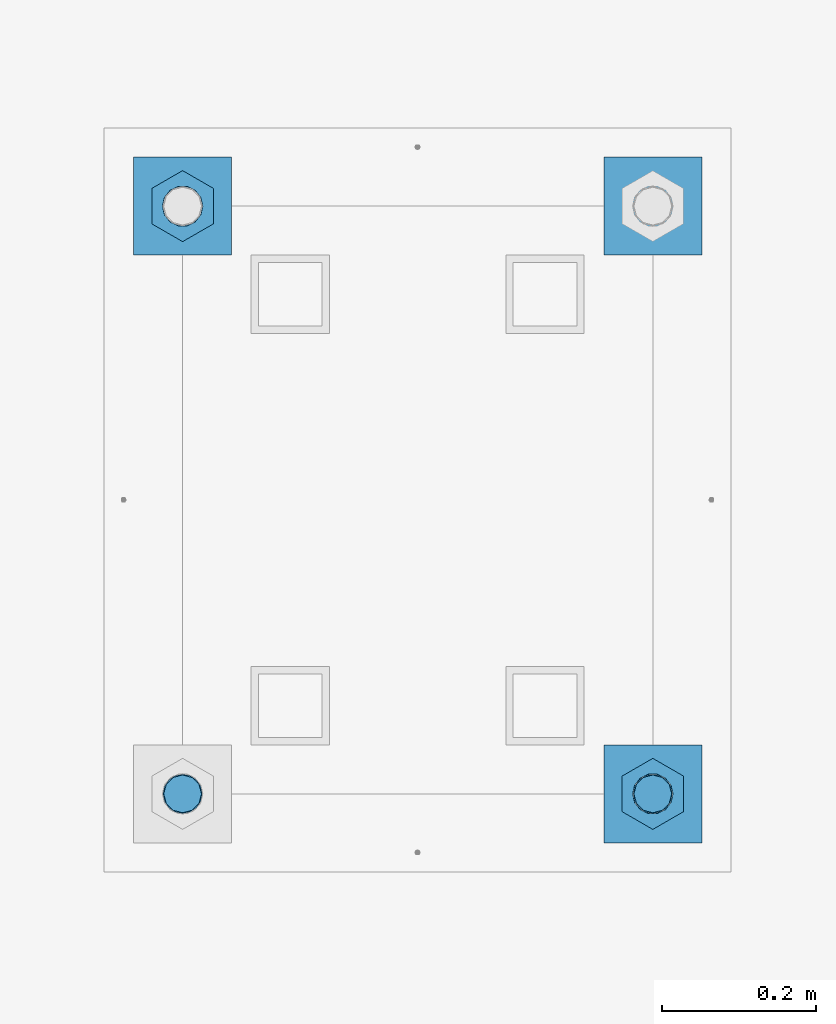
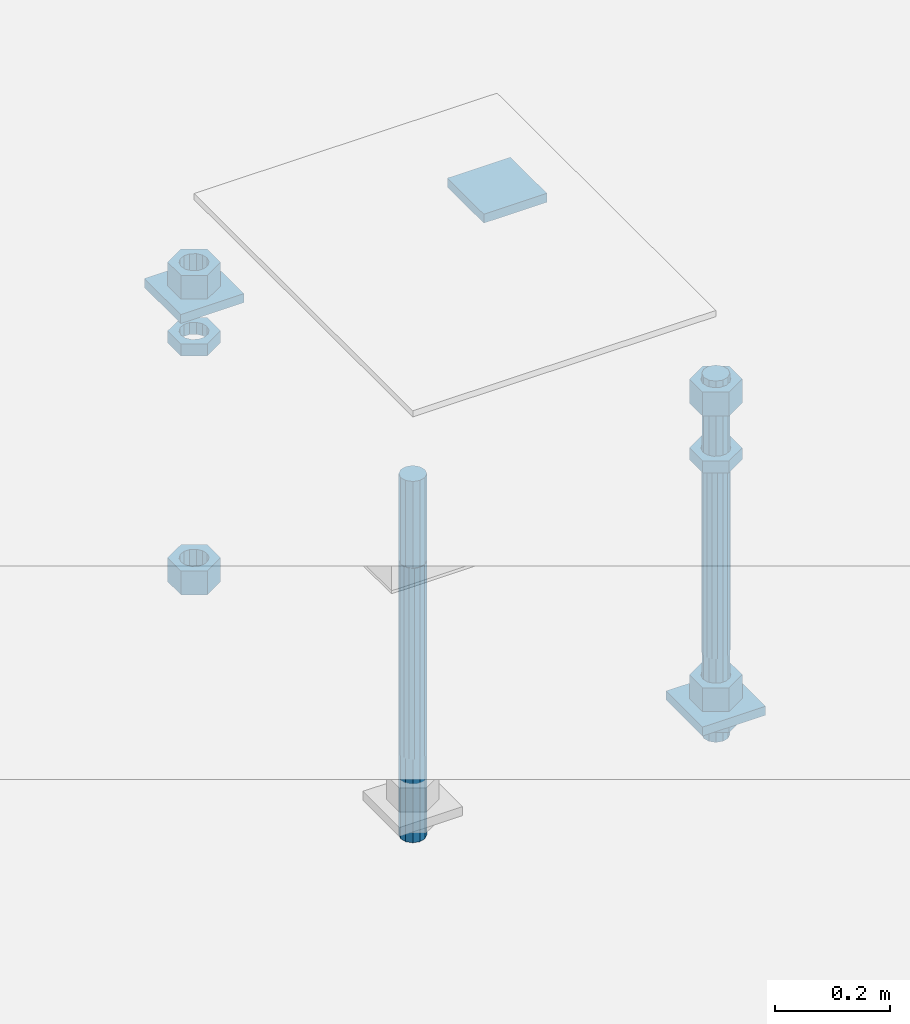
# One storey, part 2639 of 3843: 12 beams, 1 element without a shape of its own.
"""IFC2X3 building model written with IfcOpenShell, lengths in millimetres."""

from ifc_helpers import new_model, si_unit, frame, origin_with_axes, place, context, subcontext, project, spatial, faceted_brep, material, type_object, element, aggregate, save


model = new_model("IFC2X3")

# Units and contexts
model_context = context("Model", 3, precision=1e-05, world=origin_with_axes())
body_context = subcontext(model_context, "Body", "Model", "MODEL_VIEW")
ifc_project = project(units=[si_unit("LENGTHUNIT", "METRE", prefix="MILLI"), si_unit("AREAUNIT", "SQUARE_METRE"), si_unit("VOLUMEUNIT", "CUBIC_METRE"), si_unit("MASSUNIT", "GRAM", prefix="KILO"), si_unit("TIMEUNIT", "SECOND"), si_unit("PLANEANGLEUNIT", "RADIAN"), si_unit("SOLIDANGLEUNIT", "STERADIAN"), si_unit("THERMODYNAMICTEMPERATUREUNIT", "DEGREE_CELSIUS"), si_unit("LUMINOUSINTENSITYUNIT", "LUMEN")], contexts=[model_context])

# Site, building, storey
site_placement = place(None, origin_with_axes())
site = spatial("IfcSite", under=ifc_project, at=site_placement, CompositionType="ELEMENT")
building_placement = place(site_placement, origin_with_axes())
building = spatial("IfcBuilding", under=site, at=building_placement, Name="Undefined", CompositionType="ELEMENT")
storey_placement = place(building_placement, origin_with_axes())
storey = spatial("IfcBuildingStorey", under=building, at=storey_placement, Name="Undefined", CompositionType="ELEMENT", Elevation=0.0)

# Assembly, beams
assembly_placement = place(storey_placement, origin_with_axes())
assembly = element("IfcElementAssembly", 1, at=assembly_placement, inside=storey, Name="TEMPLATE", AssemblyPlace="NOTDEFINED", PredefinedType="RIGID_FRAME")
ifc_material_1 = material(Name="STEEL/A36")
beam_type_1 = type_object("IfcBeamType", PredefinedType="NOTDEFINED")
beam_1_placement = place(assembly_placement, frame((112407.7, 10883.9, 29873.575), z_axis=(0.0, 1.0, 0.0), x_axis=(-1.0, 0.0, 0.0)))
beam_1 = element("IfcBeam", 2, at=beam_1_placement, type_object=beam_type_1, material=ifc_material_1, Name="WASHER_PLATE", context=body_context, shape_type="Brep", body=[
    faceted_brep([(0.0, 9.52500000000146, -63.5), (0.0, 9.52500000000146, 63.5), (127.0, 9.52500000000146, 63.5), (127.0, 9.52500000000146, -63.5), (0.0, -9.52500000000146, 63.5), (127.0, -9.52500000000146, 63.5), (0.0, -9.52500000000146, -63.5), (127.0, -9.52500000000146, -63.5)], [[[0, 1, 2, 3]], [[1, 4, 5, 2]], [[4, 6, 7, 5]], [[6, 0, 3, 7]], [[5, 7, 3, 2]], [[6, 4, 1, 0]]]),
])
beam_2_placement = place(assembly_placement, frame((111798.099998474, 10883.9, 29873.575), z_axis=(0.0, 1.0, 0.0), x_axis=(-1.0, 0.0, 0.0)))
beam_2 = element("IfcBeam", 3, at=beam_2_placement, type_object=beam_type_1, material=ifc_material_1, Name="WASHER_PLATE", context=body_context, shape_type="Brep", body=[
    faceted_brep([(0.0, 9.52500000000146, -63.5), (0.0, 9.52500000000146, 63.5), (127.0, 9.52500000000146, 63.5), (127.0, 9.52500000000146, -63.5), (0.0, -9.52500000000146, 63.5), (127.0, -9.52500000000146, 63.5), (0.0, -9.52500000000146, -63.5), (127.0, -9.52500000000146, -63.5)], [[[0, 1, 2, 3]], [[1, 4, 5, 2]], [[4, 6, 7, 5]], [[6, 0, 3, 7]], [[5, 7, 3, 2]], [[6, 4, 1, 0]]]),
])
beam_3_placement = place(assembly_placement, frame((112407.7, 10121.9, 29244.925), z_axis=(0.0, 1.0, 0.0), x_axis=(-1.0, 0.0, 0.0)))
beam_3 = element("IfcBeam", 4, at=beam_3_placement, type_object=beam_type_1, material=ifc_material_1, Name="WASHER_PLATE", context=body_context, shape_type="Brep", body=[
    faceted_brep([(0.0, 9.52500000000146, -63.5), (0.0, 9.52500000000146, 63.5), (127.0, 9.52500000000146, 63.5), (127.0, 9.52500000000146, -63.5), (0.0, -9.52500000000146, 63.5), (127.0, -9.52500000000146, 63.5), (0.0, -9.52500000000146, -63.5), (127.0, -9.52500000000146, -63.5)], [[[0, 1, 2, 3]], [[1, 4, 5, 2]], [[4, 6, 7, 5]], [[6, 0, 3, 7]], [[5, 7, 3, 2]], [[6, 4, 1, 0]]]),
])
beam_type_2 = type_object("IfcBeamType", Name="2_HALF_NUT", PredefinedType="NOTDEFINED")
beam_4_placement = place(assembly_placement, frame((111734.599998474, 10883.9, 29787.85), z_axis=(-1.0, 0.0, 0.0), x_axis=(0.0, 0.0, -1.0)))
beam_4 = element("IfcBeam", 5, at=beam_4_placement, type_object=beam_type_2, material=ifc_material_1, Name="NUT", ObjectType="2_HALF_NUT", context=body_context, shape_type="Brep", body=[
    faceted_brep([(0.0, -46.0369987487793, 0.0), (0.0, -23.0184993743896, -39.869213104248), (25.4000000000015, -23.0184993743896, -39.869213104248), (25.4000000000015, -46.0369987487793, 0.0), (0.0, 23.0184993743896, -39.869213104248), (25.4000000000015, 23.0184993743896, -39.869213104248), (0.0, 46.0369987487793, 0.0), (25.4000000000015, 46.0369987487793, 0.0), (0.0, 23.0184993743896, 39.869213104248), (25.4000000000015, 23.0184993743896, 39.869213104248), (0.0, -23.0184993743896, 39.869213104248), (25.4000000000015, -23.0184993743896, 39.869213104248), (0.0, 0.0, 26.1940002441406), (0.0, 11.3650617044477, 23.5999013092805), (25.4000000000015, 11.3650617044477, 23.5999013092805), (25.4000000000015, 0.0, 26.1940002441406), (0.0, 20.4791109456419, 16.3316083006721), (25.4000000000015, 20.4791109456419, 16.3316083006721), (0.0, 25.5370200498292, 5.82867859874386), (25.4000000000015, 25.5370200498292, 5.82867859874386), (0.0, 25.5370200498292, -5.82867859874386), (25.4000000000015, 25.5370200498292, -5.82867859874386), (0.0, 20.4791109456419, -16.3316083006721), (25.4000000000015, 20.4791109456419, -16.3316083006721), (0.0, 11.3650617044477, -23.5999013092805), (25.4000000000015, 11.3650617044477, -23.5999013092805), (0.0, 0.0, -26.1940002441406), (25.4000000000015, 0.0, -26.1940002441406), (0.0, -11.3650617044477, -23.5999013092805), (25.4000000000015, -11.3650617044477, -23.5999013092805), (0.0, -20.4791109456419, -16.3316083006721), (25.4000000000015, -20.4791109456419, -16.3316083006721), (0.0, -25.5370200498292, -5.82867859874386), (25.4000000000015, -25.5370200498292, -5.82867859874386), (0.0, -25.5370200498292, 5.82867859874386), (25.4000000000015, -25.5370200498292, 5.82867859874386), (0.0, -20.4791109456419, 16.3316083006721), (25.4000000000015, -20.4791109456419, 16.3316083006721), (0.0, -11.3650617044477, 23.5999013092805), (25.4000000000015, -11.3650617044477, 23.5999013092805)], [[[0, 1, 2, 3]], [[1, 4, 5, 2]], [[4, 6, 7, 5]], [[6, 8, 9, 7]], [[8, 10, 11, 9]], [[10, 0, 3, 11]], [[12, 13, 14, 15]], [[13, 16, 17, 14]], [[16, 18, 19, 17]], [[18, 20, 21, 19]], [[20, 22, 23, 21]], [[22, 24, 25, 23]], [[24, 26, 27, 25]], [[26, 28, 29, 27]], [[28, 30, 31, 29]], [[30, 32, 33, 31]], [[32, 34, 35, 33]], [[34, 36, 37, 35]], [[36, 38, 39, 37]], [[38, 12, 15, 39]], [[5, 7, 9, 11, 3, 2], [17, 19, 21, 23, 25, 27, 29, 31, 33, 35, 37, 39, 15, 14]], [[10, 8, 6, 4, 1, 0], [38, 36, 34, 32, 30, 28, 26, 24, 22, 20, 18, 16, 13, 12]]]),
])
beam_5_placement = place(assembly_placement, frame((112344.2, 10121.9, 29787.85), z_axis=(-1.0, 0.0, 0.0), x_axis=(0.0, 0.0, -1.0)))
beam_5 = element("IfcBeam", 6, at=beam_5_placement, type_object=beam_type_2, material=ifc_material_1, Name="NUT", ObjectType="2_HALF_NUT", context=body_context, shape_type="Brep", body=[
    faceted_brep([(0.0, -46.0369987487793, 0.0), (0.0, -23.0184993743896, -39.869213104248), (25.4000000000015, -23.0184993743896, -39.869213104248), (25.4000000000015, -46.0369987487793, 0.0), (0.0, 23.0184993743896, -39.869213104248), (25.4000000000015, 23.0184993743896, -39.869213104248), (0.0, 46.0369987487793, 0.0), (25.4000000000015, 46.0369987487793, 0.0), (0.0, 23.0184993743896, 39.869213104248), (25.4000000000015, 23.0184993743896, 39.869213104248), (0.0, -23.0184993743896, 39.869213104248), (25.4000000000015, -23.0184993743896, 39.869213104248), (0.0, 0.0, 26.1940002441406), (0.0, 11.3650617044477, 23.5999013092805), (25.4000000000015, 11.3650617044477, 23.5999013092805), (25.4000000000015, 0.0, 26.1940002441406), (0.0, 20.4791109456419, 16.3316083006721), (25.4000000000015, 20.4791109456419, 16.3316083006721), (0.0, 25.5370200498292, 5.82867859874386), (25.4000000000015, 25.5370200498292, 5.82867859874386), (0.0, 25.5370200498292, -5.82867859874386), (25.4000000000015, 25.5370200498292, -5.82867859874386), (0.0, 20.4791109456419, -16.3316083006721), (25.4000000000015, 20.4791109456419, -16.3316083006721), (0.0, 11.3650617044477, -23.5999013092805), (25.4000000000015, 11.3650617044477, -23.5999013092805), (0.0, 0.0, -26.1940002441406), (25.4000000000015, 0.0, -26.1940002441406), (0.0, -11.3650617044477, -23.5999013092805), (25.4000000000015, -11.3650617044477, -23.5999013092805), (0.0, -20.4791109456419, -16.3316083006721), (25.4000000000015, -20.4791109456419, -16.3316083006721), (0.0, -25.5370200498292, -5.82867859874386), (25.4000000000015, -25.5370200498292, -5.82867859874386), (0.0, -25.5370200498292, 5.82867859874386), (25.4000000000015, -25.5370200498292, 5.82867859874386), (0.0, -20.4791109456419, 16.3316083006721), (25.4000000000015, -20.4791109456419, 16.3316083006721), (0.0, -11.3650617044477, 23.5999013092805), (25.4000000000015, -11.3650617044477, 23.5999013092805)], [[[0, 1, 2, 3]], [[1, 4, 5, 2]], [[4, 6, 7, 5]], [[6, 8, 9, 7]], [[8, 10, 11, 9]], [[10, 0, 3, 11]], [[12, 13, 14, 15]], [[13, 16, 17, 14]], [[16, 18, 19, 17]], [[18, 20, 21, 19]], [[20, 22, 23, 21]], [[22, 24, 25, 23]], [[24, 26, 27, 25]], [[26, 28, 29, 27]], [[28, 30, 31, 29]], [[30, 32, 33, 31]], [[32, 34, 35, 33]], [[34, 36, 37, 35]], [[36, 38, 39, 37]], [[38, 12, 15, 39]], [[5, 7, 9, 11, 3, 2], [17, 19, 21, 23, 25, 27, 29, 31, 33, 35, 37, 39, 15, 14]], [[10, 8, 6, 4, 1, 0], [38, 36, 34, 32, 30, 28, 26, 24, 22, 20, 18, 16, 13, 12]]]),
])
beam_6_placement = place(assembly_placement, frame((112344.2, 10121.9, 29235.4), z_axis=(-1.0, 0.0, 0.0), x_axis=(0.0, 0.0, -1.0)))
beam_6 = element("IfcBeam", 7, at=beam_6_placement, type_object=beam_type_2, material=ifc_material_1, Name="NUT", ObjectType="2_HALF_NUT", context=body_context, shape_type="Brep", body=[
    faceted_brep([(0.0, -46.0369987487793, 0.0), (0.0, -23.0184993743896, -39.869213104248), (25.4000000000015, -23.0184993743896, -39.869213104248), (25.4000000000015, -46.0369987487793, 0.0), (0.0, 23.0184993743896, -39.869213104248), (25.4000000000015, 23.0184993743896, -39.869213104248), (0.0, 46.0369987487793, 0.0), (25.4000000000015, 46.0369987487793, 0.0), (0.0, 23.0184993743896, 39.869213104248), (25.4000000000015, 23.0184993743896, 39.869213104248), (0.0, -23.0184993743896, 39.869213104248), (25.4000000000015, -23.0184993743896, 39.869213104248), (0.0, 0.0, 26.1940002441406), (0.0, 11.3650617044477, 23.5999013092805), (25.4000000000015, 11.3650617044477, 23.5999013092805), (25.4000000000015, 0.0, 26.1940002441406), (0.0, 20.4791109456419, 16.3316083006721), (25.4000000000015, 20.4791109456419, 16.3316083006721), (0.0, 25.5370200498292, 5.82867859874386), (25.4000000000015, 25.5370200498292, 5.82867859874386), (0.0, 25.5370200498292, -5.82867859874386), (25.4000000000015, 25.5370200498292, -5.82867859874386), (0.0, 20.4791109456419, -16.3316083006721), (25.4000000000015, 20.4791109456419, -16.3316083006721), (0.0, 11.3650617044477, -23.5999013092805), (25.4000000000015, 11.3650617044477, -23.5999013092805), (0.0, 0.0, -26.1940002441406), (25.4000000000015, 0.0, -26.1940002441406), (0.0, -11.3650617044477, -23.5999013092805), (25.4000000000015, -11.3650617044477, -23.5999013092805), (0.0, -20.4791109456419, -16.3316083006721), (25.4000000000015, -20.4791109456419, -16.3316083006721), (0.0, -25.5370200498292, -5.82867859874386), (25.4000000000015, -25.5370200498292, -5.82867859874386), (0.0, -25.5370200498292, 5.82867859874386), (25.4000000000015, -25.5370200498292, 5.82867859874386), (0.0, -20.4791109456419, 16.3316083006721), (25.4000000000015, -20.4791109456419, 16.3316083006721), (0.0, -11.3650617044477, 23.5999013092805), (25.4000000000015, -11.3650617044477, 23.5999013092805)], [[[0, 1, 2, 3]], [[1, 4, 5, 2]], [[4, 6, 7, 5]], [[6, 8, 9, 7]], [[8, 10, 11, 9]], [[10, 0, 3, 11]], [[12, 13, 14, 15]], [[13, 16, 17, 14]], [[16, 18, 19, 17]], [[18, 20, 21, 19]], [[20, 22, 23, 21]], [[22, 24, 25, 23]], [[24, 26, 27, 25]], [[26, 28, 29, 27]], [[28, 30, 31, 29]], [[30, 32, 33, 31]], [[32, 34, 35, 33]], [[34, 36, 37, 35]], [[36, 38, 39, 37]], [[38, 12, 15, 39]], [[5, 7, 9, 11, 3, 2], [17, 19, 21, 23, 25, 27, 29, 31, 33, 35, 37, 39, 15, 14]], [[10, 8, 6, 4, 1, 0], [38, 36, 34, 32, 30, 28, 26, 24, 22, 20, 18, 16, 13, 12]]]),
])
beam_type_3 = type_object("IfcBeamType", Name="2_HEAVY_HEX_NUT", PredefinedType="NOTDEFINED")
beam_7_placement = place(assembly_placement, frame((111734.599998474, 10883.9, 29933.9), z_axis=(-1.0, 0.0, 0.0), x_axis=(0.0, 0.0, -1.0)))
beam_7 = element("IfcBeam", 8, at=beam_7_placement, type_object=beam_type_3, material=ifc_material_1, Name="NUT", ObjectType="2_HEAVY_HEX_NUT", context=body_context, shape_type="Brep", body=[
    faceted_brep([(0.0, -46.0369987487793, 0.0), (0.0, -23.0184993743896, -39.869213104248), (50.7999999999993, -23.0184993743896, -39.869213104248), (50.7999999999993, -46.0369987487793, 0.0), (0.0, 23.0184993743896, -39.869213104248), (50.7999999999993, 23.0184993743896, -39.869213104248), (0.0, 46.0369987487793, 0.0), (50.7999999999993, 46.0369987487793, 0.0), (0.0, 23.0184993743896, 39.869213104248), (50.7999999999993, 23.0184993743896, 39.869213104248), (0.0, -23.0184993743896, 39.869213104248), (50.7999999999993, -23.0184993743896, 39.869213104248), (0.0, 0.0, 26.1940002441406), (0.0, 11.3650617044477, 23.5999013092805), (50.7999999999993, 11.3650617044477, 23.5999013092805), (50.7999999999993, 0.0, 26.1940002441406), (0.0, 20.4791109456419, 16.3316083006721), (50.7999999999993, 20.4791109456419, 16.3316083006721), (0.0, 25.5370200498292, 5.82867859874386), (50.7999999999993, 25.5370200498292, 5.82867859874386), (0.0, 25.5370200498292, -5.82867859874386), (50.7999999999993, 25.5370200498292, -5.82867859874386), (0.0, 20.4791109456419, -16.3316083006721), (50.7999999999993, 20.4791109456419, -16.3316083006721), (0.0, 11.3650617044477, -23.5999013092805), (50.7999999999993, 11.3650617044477, -23.5999013092805), (0.0, 0.0, -26.1940002441406), (50.7999999999993, 0.0, -26.1940002441406), (0.0, -11.3650617044477, -23.5999013092805), (50.7999999999993, -11.3650617044477, -23.5999013092805), (0.0, -20.4791109456419, -16.3316083006721), (50.7999999999993, -20.4791109456419, -16.3316083006721), (0.0, -25.5370200498292, -5.82867859874386), (50.7999999999993, -25.5370200498292, -5.82867859874386), (0.0, -25.5370200498292, 5.82867859874386), (50.7999999999993, -25.5370200498292, 5.82867859874386), (0.0, -20.4791109456419, 16.3316083006721), (50.7999999999993, -20.4791109456419, 16.3316083006721), (0.0, -11.3650617044477, 23.5999013092805), (50.7999999999993, -11.3650617044477, 23.5999013092805)], [[[0, 1, 2, 3]], [[1, 4, 5, 2]], [[4, 6, 7, 5]], [[6, 8, 9, 7]], [[8, 10, 11, 9]], [[10, 0, 3, 11]], [[12, 13, 14, 15]], [[13, 16, 17, 14]], [[16, 18, 19, 17]], [[18, 20, 21, 19]], [[20, 22, 23, 21]], [[22, 24, 25, 23]], [[24, 26, 27, 25]], [[26, 28, 29, 27]], [[28, 30, 31, 29]], [[30, 32, 33, 31]], [[32, 34, 35, 33]], [[34, 36, 37, 35]], [[36, 38, 39, 37]], [[38, 12, 15, 39]], [[5, 7, 9, 11, 3, 2], [17, 19, 21, 23, 25, 27, 29, 31, 33, 35, 37, 39, 15, 14]], [[10, 8, 6, 4, 1, 0], [38, 36, 34, 32, 30, 28, 26, 24, 22, 20, 18, 16, 13, 12]]]),
])
beam_8_placement = place(assembly_placement, frame((111734.599998474, 10883.9, 29305.25), z_axis=(-1.0, 0.0, 0.0), x_axis=(0.0, 0.0, -1.0)))
beam_8 = element("IfcBeam", 9, at=beam_8_placement, type_object=beam_type_3, material=ifc_material_1, Name="NUT", ObjectType="2_HEAVY_HEX_NUT", context=body_context, shape_type="Brep", body=[
    faceted_brep([(0.0, -46.0369987487793, 0.0), (0.0, -23.0184993743896, -39.869213104248), (50.7999999999993, -23.0184993743896, -39.869213104248), (50.7999999999993, -46.0369987487793, 0.0), (0.0, 23.0184993743896, -39.869213104248), (50.7999999999993, 23.0184993743896, -39.869213104248), (0.0, 46.0369987487793, 0.0), (50.7999999999993, 46.0369987487793, 0.0), (0.0, 23.0184993743896, 39.869213104248), (50.7999999999993, 23.0184993743896, 39.869213104248), (0.0, -23.0184993743896, 39.869213104248), (50.7999999999993, -23.0184993743896, 39.869213104248), (0.0, 0.0, 26.1940002441406), (0.0, 11.3650617044477, 23.5999013092805), (50.7999999999993, 11.3650617044477, 23.5999013092805), (50.7999999999993, 0.0, 26.1940002441406), (0.0, 20.4791109456419, 16.3316083006721), (50.7999999999993, 20.4791109456419, 16.3316083006721), (0.0, 25.5370200498292, 5.82867859874386), (50.7999999999993, 25.5370200498292, 5.82867859874386), (0.0, 25.5370200498292, -5.82867859874386), (50.7999999999993, 25.5370200498292, -5.82867859874386), (0.0, 20.4791109456419, -16.3316083006721), (50.7999999999993, 20.4791109456419, -16.3316083006721), (0.0, 11.3650617044477, -23.5999013092805), (50.7999999999993, 11.3650617044477, -23.5999013092805), (0.0, 0.0, -26.1940002441406), (50.7999999999993, 0.0, -26.1940002441406), (0.0, -11.3650617044477, -23.5999013092805), (50.7999999999993, -11.3650617044477, -23.5999013092805), (0.0, -20.4791109456419, -16.3316083006721), (50.7999999999993, -20.4791109456419, -16.3316083006721), (0.0, -25.5370200498292, -5.82867859874386), (50.7999999999993, -25.5370200498292, -5.82867859874386), (0.0, -25.5370200498292, 5.82867859874386), (50.7999999999993, -25.5370200498292, 5.82867859874386), (0.0, -20.4791109456419, 16.3316083006721), (50.7999999999993, -20.4791109456419, 16.3316083006721), (0.0, -11.3650617044477, 23.5999013092805), (50.7999999999993, -11.3650617044477, 23.5999013092805)], [[[0, 1, 2, 3]], [[1, 4, 5, 2]], [[4, 6, 7, 5]], [[6, 8, 9, 7]], [[8, 10, 11, 9]], [[10, 0, 3, 11]], [[12, 13, 14, 15]], [[13, 16, 17, 14]], [[16, 18, 19, 17]], [[18, 20, 21, 19]], [[20, 22, 23, 21]], [[22, 24, 25, 23]], [[24, 26, 27, 25]], [[26, 28, 29, 27]], [[28, 30, 31, 29]], [[30, 32, 33, 31]], [[32, 34, 35, 33]], [[34, 36, 37, 35]], [[36, 38, 39, 37]], [[38, 12, 15, 39]], [[5, 7, 9, 11, 3, 2], [17, 19, 21, 23, 25, 27, 29, 31, 33, 35, 37, 39, 15, 14]], [[10, 8, 6, 4, 1, 0], [38, 36, 34, 32, 30, 28, 26, 24, 22, 20, 18, 16, 13, 12]]]),
])
beam_9_placement = place(assembly_placement, frame((112344.2, 10121.9, 29933.9), z_axis=(-1.0, 0.0, 0.0), x_axis=(0.0, 0.0, -1.0)))
beam_9 = element("IfcBeam", 10, at=beam_9_placement, type_object=beam_type_3, material=ifc_material_1, Name="NUT", ObjectType="2_HEAVY_HEX_NUT", context=body_context, shape_type="Brep", body=[
    faceted_brep([(0.0, -46.0369987487793, 0.0), (0.0, -23.0184993743896, -39.869213104248), (50.7999999999993, -23.0184993743896, -39.869213104248), (50.7999999999993, -46.0369987487793, 0.0), (0.0, 23.0184993743896, -39.869213104248), (50.7999999999993, 23.0184993743896, -39.869213104248), (0.0, 46.0369987487793, 0.0), (50.7999999999993, 46.0369987487793, 0.0), (0.0, 23.0184993743896, 39.869213104248), (50.7999999999993, 23.0184993743896, 39.869213104248), (0.0, -23.0184993743896, 39.869213104248), (50.7999999999993, -23.0184993743896, 39.869213104248), (0.0, 0.0, 26.1940002441406), (0.0, 11.3650617044477, 23.5999013092805), (50.7999999999993, 11.3650617044477, 23.5999013092805), (50.7999999999993, 0.0, 26.1940002441406), (0.0, 20.4791109456419, 16.3316083006721), (50.7999999999993, 20.4791109456419, 16.3316083006721), (0.0, 25.5370200498292, 5.82867859874386), (50.7999999999993, 25.5370200498292, 5.82867859874386), (0.0, 25.5370200498292, -5.82867859874386), (50.7999999999993, 25.5370200498292, -5.82867859874386), (0.0, 20.4791109456419, -16.3316083006721), (50.7999999999993, 20.4791109456419, -16.3316083006721), (0.0, 11.3650617044477, -23.5999013092805), (50.7999999999993, 11.3650617044477, -23.5999013092805), (0.0, 0.0, -26.1940002441406), (50.7999999999993, 0.0, -26.1940002441406), (0.0, -11.3650617044477, -23.5999013092805), (50.7999999999993, -11.3650617044477, -23.5999013092805), (0.0, -20.4791109456419, -16.3316083006721), (50.7999999999993, -20.4791109456419, -16.3316083006721), (0.0, -25.5370200498292, -5.82867859874386), (50.7999999999993, -25.5370200498292, -5.82867859874386), (0.0, -25.5370200498292, 5.82867859874386), (50.7999999999993, -25.5370200498292, 5.82867859874386), (0.0, -20.4791109456419, 16.3316083006721), (50.7999999999993, -20.4791109456419, 16.3316083006721), (0.0, -11.3650617044477, 23.5999013092805), (50.7999999999993, -11.3650617044477, 23.5999013092805)], [[[0, 1, 2, 3]], [[1, 4, 5, 2]], [[4, 6, 7, 5]], [[6, 8, 9, 7]], [[8, 10, 11, 9]], [[10, 0, 3, 11]], [[12, 13, 14, 15]], [[13, 16, 17, 14]], [[16, 18, 19, 17]], [[18, 20, 21, 19]], [[20, 22, 23, 21]], [[22, 24, 25, 23]], [[24, 26, 27, 25]], [[26, 28, 29, 27]], [[28, 30, 31, 29]], [[30, 32, 33, 31]], [[32, 34, 35, 33]], [[34, 36, 37, 35]], [[36, 38, 39, 37]], [[38, 12, 15, 39]], [[5, 7, 9, 11, 3, 2], [17, 19, 21, 23, 25, 27, 29, 31, 33, 35, 37, 39, 15, 14]], [[10, 8, 6, 4, 1, 0], [38, 36, 34, 32, 30, 28, 26, 24, 22, 20, 18, 16, 13, 12]]]),
])
beam_10_placement = place(assembly_placement, frame((112344.2, 10121.9, 29305.25), z_axis=(-1.0, 0.0, 0.0), x_axis=(0.0, 0.0, -1.0)))
beam_10 = element("IfcBeam", 11, at=beam_10_placement, type_object=beam_type_3, material=ifc_material_1, Name="NUT", ObjectType="2_HEAVY_HEX_NUT", context=body_context, shape_type="Brep", body=[
    faceted_brep([(0.0, -46.0369987487793, 0.0), (0.0, -23.0184993743896, -39.869213104248), (50.7999999999993, -23.0184993743896, -39.869213104248), (50.7999999999993, -46.0369987487793, 0.0), (0.0, 23.0184993743896, -39.869213104248), (50.7999999999993, 23.0184993743896, -39.869213104248), (0.0, 46.0369987487793, 0.0), (50.7999999999993, 46.0369987487793, 0.0), (0.0, 23.0184993743896, 39.869213104248), (50.7999999999993, 23.0184993743896, 39.869213104248), (0.0, -23.0184993743896, 39.869213104248), (50.7999999999993, -23.0184993743896, 39.869213104248), (0.0, 0.0, 26.1940002441406), (0.0, 11.3650617044477, 23.5999013092805), (50.7999999999993, 11.3650617044477, 23.5999013092805), (50.7999999999993, 0.0, 26.1940002441406), (0.0, 20.4791109456419, 16.3316083006721), (50.7999999999993, 20.4791109456419, 16.3316083006721), (0.0, 25.5370200498292, 5.82867859874386), (50.7999999999993, 25.5370200498292, 5.82867859874386), (0.0, 25.5370200498292, -5.82867859874386), (50.7999999999993, 25.5370200498292, -5.82867859874386), (0.0, 20.4791109456419, -16.3316083006721), (50.7999999999993, 20.4791109456419, -16.3316083006721), (0.0, 11.3650617044477, -23.5999013092805), (50.7999999999993, 11.3650617044477, -23.5999013092805), (0.0, 0.0, -26.1940002441406), (50.7999999999993, 0.0, -26.1940002441406), (0.0, -11.3650617044477, -23.5999013092805), (50.7999999999993, -11.3650617044477, -23.5999013092805), (0.0, -20.4791109456419, -16.3316083006721), (50.7999999999993, -20.4791109456419, -16.3316083006721), (0.0, -25.5370200498292, -5.82867859874386), (50.7999999999993, -25.5370200498292, -5.82867859874386), (0.0, -25.5370200498292, 5.82867859874386), (50.7999999999993, -25.5370200498292, 5.82867859874386), (0.0, -20.4791109456419, 16.3316083006721), (50.7999999999993, -20.4791109456419, 16.3316083006721), (0.0, -11.3650617044477, 23.5999013092805), (50.7999999999993, -11.3650617044477, 23.5999013092805)], [[[0, 1, 2, 3]], [[1, 4, 5, 2]], [[4, 6, 7, 5]], [[6, 8, 9, 7]], [[8, 10, 11, 9]], [[10, 0, 3, 11]], [[12, 13, 14, 15]], [[13, 16, 17, 14]], [[16, 18, 19, 17]], [[18, 20, 21, 19]], [[20, 22, 23, 21]], [[22, 24, 25, 23]], [[24, 26, 27, 25]], [[26, 28, 29, 27]], [[28, 30, 31, 29]], [[30, 32, 33, 31]], [[32, 34, 35, 33]], [[34, 36, 37, 35]], [[36, 38, 39, 37]], [[38, 12, 15, 39]], [[5, 7, 9, 11, 3, 2], [17, 19, 21, 23, 25, 27, 29, 31, 33, 35, 37, 39, 15, 14]], [[10, 8, 6, 4, 1, 0], [38, 36, 34, 32, 30, 28, 26, 24, 22, 20, 18, 16, 13, 12]]]),
])
ifc_material_2 = material()
beam_type_4 = type_object("IfcBeamType", PredefinedType="NOTDEFINED")
beam_11_placement = place(assembly_placement, frame((111734.599998474, 10121.9, 29762.45), z_axis=(-1.0, 0.0, 0.0), x_axis=(0.0, 0.0, -1.0)))
beam_11 = element("IfcBeam", 12, at=beam_11_placement, type_object=beam_type_4, material=ifc_material_2, Name="ANCHOR_ROD", context=body_context, shape_type="Brep", body=[
    faceted_brep([(-184.150000000001, -21.217622392709, 12.25), (-184.150000000001, -12.2499999999854, 21.2176223927163), (-184.150000000001, 1.45519152283669e-11, 24.5), (-184.150000000001, 12.2500000000146, 21.2176223927163), (-184.150000000001, 21.2176223927381, 12.25), (-184.150000000001, 24.5000000000146, 0.0), (-184.150000000001, 21.2176223927381, -12.25), (-184.150000000001, 12.2500000000146, -21.2176223927163), (-184.150000000001, 1.45519152283669e-11, -24.5), (-184.150000000001, -12.2499999999854, -21.2176223927163), (-184.150000000001, -21.217622392709, -12.25), (-184.150000000001, -24.4999999999854, 0.0), (0.0, 24.5000000000146, 0.0), (0.0, 21.2176223927381, -12.25), (0.0, 12.2500000000146, -21.2176223927163), (0.0, 1.45519152283669e-11, -24.5), (0.0, -12.2499999999854, -21.2176223927163), (0.0, -21.217622392709, -12.25), (0.0, -24.4999999999854, 0.0), (0.0, -21.217622392709, 12.25), (0.0, -12.2499999999854, 21.2176223927163), (0.0, 1.45519152283669e-11, 24.5), (0.0, 12.2500000000146, 21.2176223927163), (0.0, 21.2176223927381, 12.25), (0.0, -23.4665401257807, 9.72015918207035), (0.0, -17.9605122421344, 17.9605122421417), (0.0, -9.72015918207762, 23.466540125788), (0.0, 0.0, 25.4000000000015), (0.0, 9.72015918207762, 23.466540125788), (0.0, 17.9605122421344, 17.9605122421417), (0.0, 23.4665401257807, 9.72015918207035), (0.0, 25.3999996185303, 0.0), (0.0, 23.4665401257807, -9.72015918207035), (0.0, 17.9605122421344, -17.9605122421417), (0.0, 9.72015918207762, -23.466540125788), (0.0, 0.0, -25.4000000000015), (0.0, -9.72015918207762, -23.466540125788), (0.0, -17.9605122421344, -17.9605122421417), (0.0, -23.4665401257807, -9.72015918207035), (0.0, -25.3999996185303, 0.0), (406.399999999998, -25.3999999999942, 0.0), (406.399999999998, -23.4665401257807, 9.72015918207035), (406.399999999998, -17.9605122421344, 17.9605122421417), (406.399999999998, -9.72015918207762, 23.466540125788), (406.399999999998, 0.0, 25.4000000000015), (406.399999999998, 9.72015918207762, 23.466540125788), (406.399999999998, 17.9605122421344, 17.9605122421417), (406.399999999998, 23.4665401257807, 9.72015918207035), (406.399999999998, 25.3999999999942, 0.0), (406.399999999998, 23.4665401257807, -9.72015918207035), (406.399999999998, 17.9605122421344, -17.9605122421417), (406.399999999998, 9.72015918207762, -23.466540125788), (406.399999999998, 0.0, -25.4000000000015), (406.399999999998, -9.72015918207762, -23.466540125788), (406.399999999998, -17.9605122421344, -17.9605122421417), (406.399999999998, -23.4665401257807, -9.72015918207035), (406.399999999998, -12.2499999999854, 21.2176223927163), (406.399999999998, 1.45519152283669e-11, 24.5), (406.399999999998, 12.2500000000146, 21.2176223927163), (406.399999999998, 21.2176223927381, 12.25), (406.399999999998, 24.5000000000146, 0.0), (406.399999999998, 21.2176223927381, -12.25), (406.399999999998, 12.2500000000146, -21.2176223927163), (406.399999999998, 1.45519152283669e-11, -24.5), (406.399999999998, -12.2499999999854, -21.2176223927163), (406.399999999998, -21.217622392709, -12.25), (406.399999999998, -24.4999999999854, 0.0), (406.399999999998, -21.217622392709, 12.25), (584.200000000001, -12.2499999999854, -21.2176223927163), (584.200000000001, 1.45519152283669e-11, -24.5), (584.200000000001, 12.2500000000146, -21.2176223927163), (584.200000000001, 21.2176223927381, -12.25), (584.200000000001, 24.5000000000146, 0.0), (584.200000000001, 21.2176223927381, 12.25), (584.200000000001, 12.2500000000146, 21.2176223927163), (584.200000000001, 1.45519152283669e-11, 24.5), (584.200000000001, -12.2499999999854, 21.2176223927163), (584.200000000001, -21.217622392709, 12.25), (584.200000000001, -24.4999999999854, 0.0), (584.200000000001, -21.217622392709, -12.25)], [[[0, 1, 2, 3, 4, 5, 6, 7, 8, 9, 10, 11]], [[6, 5, 12, 13]], [[7, 6, 13, 14]], [[8, 7, 14, 15]], [[9, 8, 15, 16]], [[10, 9, 16, 17]], [[11, 10, 17, 18]], [[0, 11, 18, 19]], [[1, 0, 19, 20]], [[2, 1, 20, 21]], [[3, 2, 21, 22]], [[4, 3, 22, 23]], [[5, 4, 23, 12]], [[24, 25, 26, 27, 28, 29, 30, 31, 32, 33, 34, 35, 36, 37, 38, 39], [22, 21, 20, 19, 18, 17, 16, 15, 14, 13, 12, 23]], [[24, 39, 40, 41]], [[25, 24, 41, 42]], [[26, 25, 42, 43]], [[27, 26, 43, 44]], [[28, 27, 44, 45]], [[29, 28, 45, 46]], [[30, 29, 46, 47]], [[31, 30, 47, 48]], [[32, 31, 48, 49]], [[33, 32, 49, 50]], [[34, 33, 50, 51]], [[35, 34, 51, 52]], [[36, 35, 52, 53]], [[37, 36, 53, 54]], [[38, 37, 54, 55]], [[39, 38, 55, 40]], [[54, 53, 52, 51, 50, 49, 48, 47, 46, 45, 44, 43, 42, 41, 40, 55], [56, 57, 58, 59, 60, 61, 62, 63, 64, 65, 66, 67]], [[68, 69, 70, 71, 72, 73, 74, 75, 76, 77, 78, 79]], [[76, 75, 57, 56]], [[77, 76, 56, 67]], [[78, 77, 67, 66]], [[79, 78, 66, 65]], [[68, 79, 65, 64]], [[69, 68, 64, 63]], [[70, 69, 63, 62]], [[71, 70, 62, 61]], [[72, 71, 61, 60]], [[73, 72, 60, 59]], [[74, 73, 59, 58]], [[75, 74, 58, 57]]]),
])
beam_12_placement = place(assembly_placement, frame((112344.2, 10121.9, 29762.45), z_axis=(-1.0, 0.0, 0.0), x_axis=(0.0, 0.0, -1.0)))
beam_12 = element("IfcBeam", 13, at=beam_12_placement, type_object=beam_type_4, material=ifc_material_2, Name="ANCHOR_ROD", context=body_context, shape_type="Brep", body=[
    faceted_brep([(-184.150000000001, -21.217622392709, 12.25), (-184.150000000001, -12.2499999999854, 21.2176223927163), (-184.150000000001, 1.45519152283669e-11, 24.5), (-184.150000000001, 12.2500000000146, 21.2176223927163), (-184.150000000001, 21.2176223927381, 12.25), (-184.150000000001, 24.5000000000146, 0.0), (-184.150000000001, 21.2176223927381, -12.25), (-184.150000000001, 12.2500000000146, -21.2176223927163), (-184.150000000001, 1.45519152283669e-11, -24.5), (-184.150000000001, -12.2499999999854, -21.2176223927163), (-184.150000000001, -21.217622392709, -12.25), (-184.150000000001, -24.4999999999854, 0.0), (0.0, 24.5000000000146, 0.0), (0.0, 21.2176223927381, -12.25), (0.0, 12.2500000000146, -21.2176223927163), (0.0, 1.45519152283669e-11, -24.5), (0.0, -12.2499999999854, -21.2176223927163), (0.0, -21.217622392709, -12.25), (0.0, -24.4999999999854, 0.0), (0.0, -21.217622392709, 12.25), (0.0, -12.2499999999854, 21.2176223927163), (0.0, 1.45519152283669e-11, 24.5), (0.0, 12.2500000000146, 21.2176223927163), (0.0, 21.2176223927381, 12.25), (0.0, -23.4665401257807, 9.72015918207035), (0.0, -17.9605122421344, 17.9605122421417), (0.0, -9.72015918207762, 23.466540125788), (0.0, 0.0, 25.4000000000015), (0.0, 9.72015918207762, 23.466540125788), (0.0, 17.9605122421344, 17.9605122421417), (0.0, 23.4665401257807, 9.72015918207035), (0.0, 25.3999996185303, 0.0), (0.0, 23.4665401257807, -9.72015918207035), (0.0, 17.9605122421344, -17.9605122421417), (0.0, 9.72015918207762, -23.466540125788), (0.0, 0.0, -25.4000000000015), (0.0, -9.72015918207762, -23.466540125788), (0.0, -17.9605122421344, -17.9605122421417), (0.0, -23.4665401257807, -9.72015918207035), (0.0, -25.3999996185303, 0.0), (406.399999999998, -25.3999999999942, 0.0), (406.399999999998, -23.4665401257807, 9.72015918207035), (406.399999999998, -17.9605122421344, 17.9605122421417), (406.399999999998, -9.72015918207762, 23.466540125788), (406.399999999998, 0.0, 25.4000000000015), (406.399999999998, 9.72015918207762, 23.466540125788), (406.399999999998, 17.9605122421344, 17.9605122421417), (406.399999999998, 23.4665401257807, 9.72015918207035), (406.399999999998, 25.3999999999942, 0.0), (406.399999999998, 23.4665401257807, -9.72015918207035), (406.399999999998, 17.9605122421344, -17.9605122421417), (406.399999999998, 9.72015918207762, -23.466540125788), (406.399999999998, 0.0, -25.4000000000015), (406.399999999998, -9.72015918207762, -23.466540125788), (406.399999999998, -17.9605122421344, -17.9605122421417), (406.399999999998, -23.4665401257807, -9.72015918207035), (406.399999999998, -12.2499999999854, 21.2176223927163), (406.399999999998, 1.45519152283669e-11, 24.5), (406.399999999998, 12.2500000000146, 21.2176223927163), (406.399999999998, 21.2176223927381, 12.25), (406.399999999998, 24.5000000000146, 0.0), (406.399999999998, 21.2176223927381, -12.25), (406.399999999998, 12.2500000000146, -21.2176223927163), (406.399999999998, 1.45519152283669e-11, -24.5), (406.399999999998, -12.2499999999854, -21.2176223927163), (406.399999999998, -21.217622392709, -12.25), (406.399999999998, -24.4999999999854, 0.0), (406.399999999998, -21.217622392709, 12.25), (584.200000000001, -12.2499999999854, -21.2176223927163), (584.200000000001, 1.45519152283669e-11, -24.5), (584.200000000001, 12.2500000000146, -21.2176223927163), (584.200000000001, 21.2176223927381, -12.25), (584.200000000001, 24.5000000000146, 0.0), (584.200000000001, 21.2176223927381, 12.25), (584.200000000001, 12.2500000000146, 21.2176223927163), (584.200000000001, 1.45519152283669e-11, 24.5), (584.200000000001, -12.2499999999854, 21.2176223927163), (584.200000000001, -21.217622392709, 12.25), (584.200000000001, -24.4999999999854, 0.0), (584.200000000001, -21.217622392709, -12.25)], [[[0, 1, 2, 3, 4, 5, 6, 7, 8, 9, 10, 11]], [[6, 5, 12, 13]], [[7, 6, 13, 14]], [[8, 7, 14, 15]], [[9, 8, 15, 16]], [[10, 9, 16, 17]], [[11, 10, 17, 18]], [[0, 11, 18, 19]], [[1, 0, 19, 20]], [[2, 1, 20, 21]], [[3, 2, 21, 22]], [[4, 3, 22, 23]], [[5, 4, 23, 12]], [[24, 25, 26, 27, 28, 29, 30, 31, 32, 33, 34, 35, 36, 37, 38, 39], [22, 21, 20, 19, 18, 17, 16, 15, 14, 13, 12, 23]], [[24, 39, 40, 41]], [[25, 24, 41, 42]], [[26, 25, 42, 43]], [[27, 26, 43, 44]], [[28, 27, 44, 45]], [[29, 28, 45, 46]], [[30, 29, 46, 47]], [[31, 30, 47, 48]], [[32, 31, 48, 49]], [[33, 32, 49, 50]], [[34, 33, 50, 51]], [[35, 34, 51, 52]], [[36, 35, 52, 53]], [[37, 36, 53, 54]], [[38, 37, 54, 55]], [[39, 38, 55, 40]], [[54, 53, 52, 51, 50, 49, 48, 47, 46, 45, 44, 43, 42, 41, 40, 55], [56, 57, 58, 59, 60, 61, 62, 63, 64, 65, 66, 67]], [[68, 69, 70, 71, 72, 73, 74, 75, 76, 77, 78, 79]], [[76, 75, 57, 56]], [[77, 76, 56, 67]], [[78, 77, 67, 66]], [[79, 78, 66, 65]], [[68, 79, 65, 64]], [[69, 68, 64, 63]], [[70, 69, 63, 62]], [[71, 70, 62, 61]], [[72, 71, 61, 60]], [[73, 72, 60, 59]], [[74, 73, 59, 58]], [[75, 74, 58, 57]]]),
])
aggregate(assembly, [beam_1, beam_2, beam_4, beam_7, beam_8, beam_11, beam_3, beam_5, beam_9, beam_10, beam_6, beam_12])

save(model, "model.ifc")
